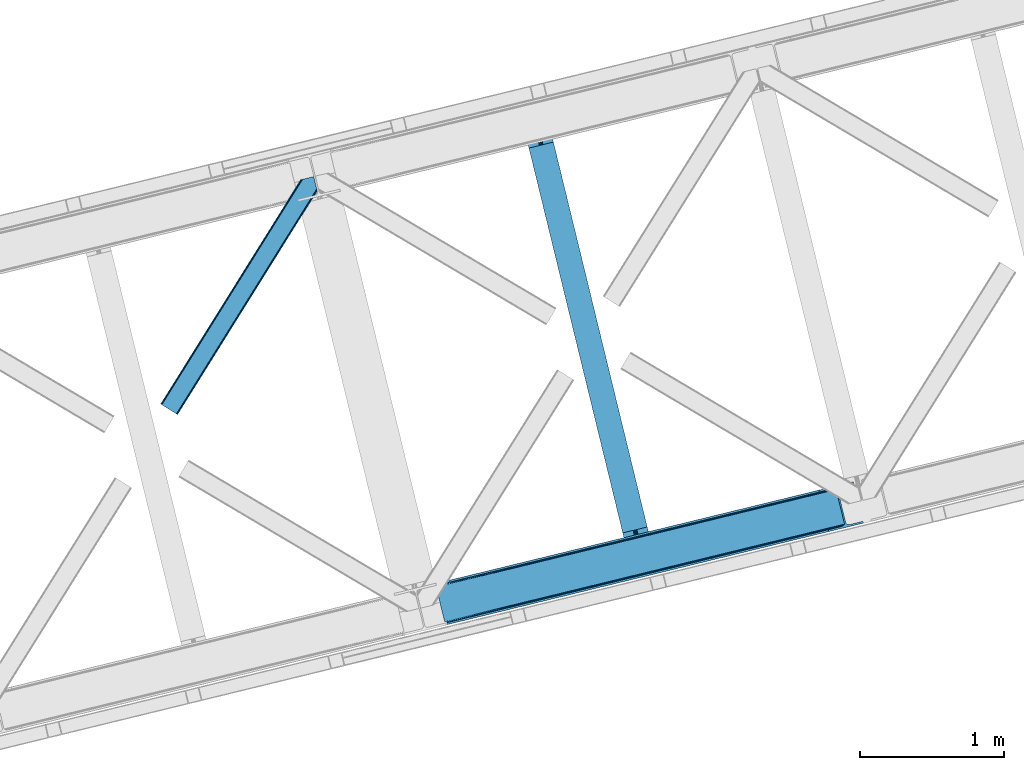
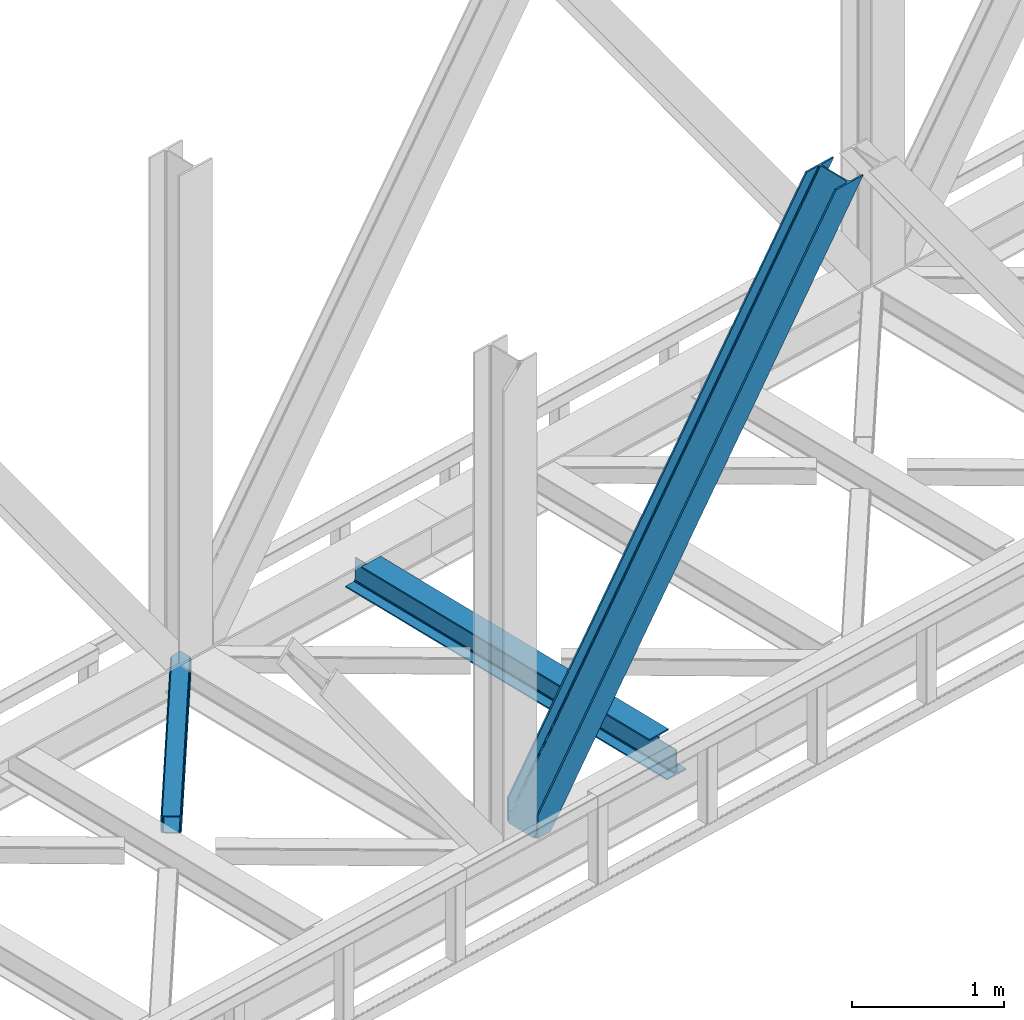
# One storey, part 62 of 93: 2 members, 1 beam.
"""IFC4 building model written with IfcOpenShell, lengths in millimetres."""

import ifcopenshell
import ifcopenshell.guid

model = None  # the IFC model being written
_history = None  # IfcOwnerHistory: only IFC2X3 demands one
_inside = {}  # id of a spatial element -> (the spatial element, [elements in it])
_under = {}  # id of a project, library or spatial element -> (it, [spatial elements below it])
_declared = {}  # id of a project -> (the project, [libraries it declares])
_typed = {}  # id of a type object -> (the type object, [elements of that type])
_made_of = {}  # id of a material, layer set ... -> (it, [elements and type objects made of it])


def new_model(schema):
    """Start an empty IFC model of exactly this schema.

    Asked for "IFC4X3", IfcOpenShell would pick the latest addendum, in which some entities
    have other attributes; the version numbers below select the first issue.
    IFC2X3 requires an IfcOwnerHistory on every rooted entity: one is made here for all.
    """
    global model, _history
    if schema == "IFC4X3":
        model = ifcopenshell.file(schema_version=(4, 3, 0, 0))
    else:
        model = ifcopenshell.file(schema=schema)
    _inside.clear()
    _under.clear()
    _declared.clear()
    _typed.clear()
    _made_of.clear()
    _history = None
    if model.schema == "IFC2X3":
        org = make("IfcOrganization", Name="unknown")
        user = make(
            "IfcPersonAndOrganization",
            ThePerson=make("IfcPerson", FamilyName="unknown"),
            TheOrganization=org,
        )
        app = make(
            "IfcApplication",
            ApplicationDeveloper=org,
            Version="unknown",
            ApplicationFullName="unknown",
            ApplicationIdentifier="unknown",
        )
        _history = make(
            "IfcOwnerHistory",
            OwningUser=user,
            OwningApplication=app,
            ChangeAction="ADDED",
            CreationDate=0,
        )
    return model


def make(cls, **values):
    """One entity of the class cls with the attributes given. An attribute that is None is left unset."""
    return model.create_entity(
        cls, **{name: value for name, value in values.items() if value is not None}
    )


def entity(cls, *values):
    """Any entity or typed value of the class cls, its attributes in the order of the schema. None: left unset."""
    e = model.create_entity(cls)
    for i, value in enumerate(values):
        if value is not None:
            e[i] = value
    return e


def rooted(cls, **values):
    """An entity with a GlobalId (a new one), such as an element, a storey or a relation."""
    return make(cls, GlobalId=ifcopenshell.guid.new(), OwnerHistory=_history, **values)


def si_unit(unit_type, name, prefix=None):
    """IfcSIUnit, for example si_unit("LENGTHUNIT", "METRE", prefix="MILLI")."""
    return make("IfcSIUnit", UnitType=unit_type, Prefix=prefix, Name=name)


def converted_unit(unit_type, name, factor, base, dimensions=None, offset=None):
    """IfcConversionBasedUnit, such as the inch: factor (a typed value) times the base unit."""
    return make(
        "IfcConversionBasedUnit"
        if offset is None
        else "IfcConversionBasedUnitWithOffset",
        ConversionOffset=offset,
        Dimensions=None
        if dimensions is None
        else entity("IfcDimensionalExponents", *dimensions),
        UnitType=unit_type,
        Name=name,
        ConversionFactor=make(
            "IfcMeasureWithUnit", ValueComponent=factor, UnitComponent=base
        ),
    )


def derived_unit(unit_type, elements):
    """IfcDerivedUnit: a product of units, each with its exponent."""
    return make(
        "IfcDerivedUnit",
        Elements=[
            make("IfcDerivedUnitElement", Unit=unit, Exponent=power)
            for unit, power in elements
        ],
        UnitType=unit_type,
    )


def assignment(units):
    """IfcUnitAssignment: the units of a project."""
    return None if units is None else make("IfcUnitAssignment", Units=units)


def point(xyz):
    """IfcCartesianPoint."""
    return None if xyz is None else make("IfcCartesianPoint", Coordinates=xyz)


def direction(xyz):
    """IfcDirection."""
    return None if xyz is None else make("IfcDirection", DirectionRatios=xyz)


def frame(location, z_axis=None, x_axis=None):
    """IfcAxis2Placement3D, a coordinate frame: its origin and axes. An axis left out is left unset."""
    return make(
        "IfcAxis2Placement3D",
        Location=point(location),
        Axis=direction(z_axis),
        RefDirection=direction(x_axis),
    )


def origin():
    """The frame at (0, 0, 0) with its axes left unset."""
    return frame((0.0, 0.0, 0.0))


def place(relative_to, where):
    """IfcLocalPlacement: puts the frame where relative to a parent placement (None: the world)."""
    return make(
        "IfcLocalPlacement", PlacementRelTo=relative_to, RelativePlacement=where
    )


def context(
    kind, dimensions, precision=None, world=None, true_north=None, identifier=None
):
    """IfcGeometricRepresentationContext, for example the 3D "Model" context."""
    return make(
        "IfcGeometricRepresentationContext",
        ContextIdentifier=identifier,
        ContextType=kind,
        CoordinateSpaceDimension=dimensions,
        Precision=precision,
        WorldCoordinateSystem=world,
        TrueNorth=true_north,
    )


def subcontext(parent, identifier, kind, view, scale=None):
    """IfcGeometricRepresentationSubContext, for example "Body" below "Model"."""
    return make(
        "IfcGeometricRepresentationSubContext",
        ContextIdentifier=identifier,
        ContextType=kind,
        ParentContext=parent,
        TargetScale=scale,
        TargetView=view,
    )


def project(units=None, contexts=None):
    """IfcProject with its units and contexts."""
    return rooted(
        "IfcProject",
        Name="project",
        RepresentationContexts=contexts,
        UnitsInContext=assignment(units),
    )


def spatial(cls, under=None, at=None, **own):
    """A site, building, storey or space (cls), placed at a placement, below another one or the project."""
    s = rooted(cls, ObjectPlacement=at, **own)
    if under is not None:
        _under.setdefault(under.id(), (under, []))[1].append(s)
    return s


def point_list(points):
    """IfcCartesianPointList2D or 3D."""
    cls = (
        "IfcCartesianPointList2D" if len(points[0]) == 2 else "IfcCartesianPointList3D"
    )
    return make(cls, CoordList=points)


def triangles(points, corners, closed=None, point_numbers=None):
    """IfcTriangulatedFaceSet: each triangle names its three corners, points numbered from 1."""
    return make(
        "IfcTriangulatedFaceSet",
        Coordinates=point_list(points),
        Closed=closed,
        CoordIndex=corners,
        PnIndex=point_numbers,
    )


def polygons(points, faces, closed=None, point_numbers=None):
    """IfcPolygonalFaceSet: a face is its outer loop, then its inner loops; points numbered from 1."""
    made = []
    for loops in faces:
        if len(loops) == 1:
            made.append(make("IfcIndexedPolygonalFace", CoordIndex=loops[0]))
        else:
            made.append(
                make(
                    "IfcIndexedPolygonalFaceWithVoids",
                    CoordIndex=loops[0],
                    InnerCoordIndices=loops[1:],
                )
            )
    return make(
        "IfcPolygonalFaceSet",
        Coordinates=point_list(points),
        Closed=closed,
        Faces=made,
        PnIndex=point_numbers,
    )


def shape(context_of_items, identifier, shape_type, items):
    """IfcShapeRepresentation: the items that make up one representation, for example the "Body"."""
    return make(
        "IfcShapeRepresentation",
        ContextOfItems=context_of_items,
        RepresentationIdentifier=identifier,
        RepresentationType=shape_type,
        Items=items,
    )


def material(Name=None, Category=None):
    """IfcMaterial."""
    return make("IfcMaterial", Name=Name, Category=Category)


def made_of(thing, what):
    """Note that an element or type object is made of a material, layer set ...; save() writes the relation."""
    if what is not None:
        _made_of.setdefault(what.id(), (what, []))[1].append(thing)
    return thing


def type_object(cls, material=None, **own):
    """A type object (cls), such as IfcWallType, which elements share."""
    return made_of(rooted(cls, **own), material)


def element(
    cls,
    number,
    at=None,
    inside=None,
    cuts=None,
    type_object=None,
    material=None,
    context=None,
    identifier="Body",
    shape_type=None,
    held_by="IfcProductDefinitionShape",
    body=None,
    shapes=None,
    **own,
):
    """One element of the class cls, such as IfcWall. Its Tag is "e" and its number.

    at: its placement. inside: the storey or other place that contains it. cuts: it is an
    opening in that element (IfcRelVoidsElement). A single representation is given by context,
    identifier, shape_type and body (its items); several are given by shapes. held_by: the class
    of the entity that holds the representations. save() writes the other relations.
    """
    e = rooted(cls, Tag="e%d" % number, ObjectPlacement=at, **own)
    if body is not None:
        shapes = [shape(context, identifier, shape_type, body)]
    if shapes is not None:
        e.Representation = make(held_by, Representations=shapes)
    if inside is not None:
        _inside.setdefault(inside.id(), (inside, []))[1].append(e)
    if cuts is not None:
        rooted(
            "IfcRelVoidsElement", RelatingBuildingElement=cuts, RelatedOpeningElement=e
        )
    if type_object is not None:
        _typed.setdefault(type_object.id(), (type_object, []))[1].append(e)
    return made_of(e, material)


def aggregate(whole, parts):
    """IfcRelAggregates: a whole, such as a stair, and the parts it consists of."""
    return rooted("IfcRelAggregates", RelatingObject=whole, RelatedObjects=parts)


def save(model, path):
    """Write the relations noted so far, then the file.

    IfcRelAggregates (storeys below a building ...), IfcRelContainedInSpatialStructure (elements
    in a storey), IfcRelDefinesByType, IfcRelAssociatesMaterial and IfcRelDeclares: one each for
    every whole, place, type object, material and project.
    """
    for whole, parts in _under.values():
        aggregate(whole, parts)
    for where, things in _inside.values():
        rooted(
            "IfcRelContainedInSpatialStructure",
            RelatedElements=things,
            RelatingStructure=where,
        )
    for kind, things in _typed.values():
        rooted("IfcRelDefinesByType", RelatedObjects=things, RelatingType=kind)
    for what, things in _made_of.values():
        rooted("IfcRelAssociatesMaterial", RelatedObjects=things, RelatingMaterial=what)
    for by, libraries in _declared.values():
        rooted("IfcRelDeclares", RelatingContext=by, RelatedDefinitions=libraries)
    model.write(path)


model = new_model("IFC4")

# Units and contexts
model_context = context("Model", 3, precision=0.01, world=origin(), true_north=direction((6.12303176911189e-17, 1.0)))
plan_context = context("Plan", 3, precision=0.01, world=origin(), true_north=direction((6.12303176911189e-17, 1.0)))
body_context = subcontext(model_context, "Body", "Model", "MODEL_VIEW")
ifc_project = project(units=[si_unit("LENGTHUNIT", "METRE", prefix="MILLI"), si_unit("AREAUNIT", "SQUARE_METRE"), si_unit("VOLUMEUNIT", "CUBIC_METRE"), converted_unit("PLANEANGLEUNIT", "DEGREE", entity("IfcRatioMeasure", 0.0174532925199433), si_unit("PLANEANGLEUNIT", "RADIAN"), dimensions=[0, 0, 0, 0, 0, 0, 0]), si_unit("MASSUNIT", "GRAM", prefix="KILO"), derived_unit("MASSDENSITYUNIT", [(si_unit("MASSUNIT", "GRAM", prefix="KILO"), 1), (si_unit("LENGTHUNIT", "METRE"), -3)]), derived_unit("MOMENTOFINERTIAUNIT", [(si_unit("LENGTHUNIT", "METRE"), 4)]), si_unit("TIMEUNIT", "SECOND"), si_unit("FREQUENCYUNIT", "HERTZ"), si_unit("THERMODYNAMICTEMPERATUREUNIT", "DEGREE_CELSIUS"), derived_unit("THERMALTRANSMITTANCEUNIT", [(si_unit("MASSUNIT", "GRAM", prefix="KILO"), 1), (si_unit("THERMODYNAMICTEMPERATUREUNIT", "KELVIN"), -1), (si_unit("TIMEUNIT", "SECOND"), -3)]), derived_unit("VOLUMETRICFLOWRATEUNIT", [(si_unit("LENGTHUNIT", "METRE"), 3), (si_unit("TIMEUNIT", "SECOND"), -1)]), derived_unit("MASSFLOWRATEUNIT", [(si_unit("MASSUNIT", "GRAM", prefix="KILO"), 1), (si_unit("TIMEUNIT", "SECOND"), -1)]), derived_unit("ROTATIONALFREQUENCYUNIT", [(si_unit("TIMEUNIT", "SECOND"), -1)]), si_unit("ELECTRICCURRENTUNIT", "AMPERE"), si_unit("ELECTRICVOLTAGEUNIT", "VOLT"), si_unit("POWERUNIT", "WATT"), si_unit("FORCEUNIT", "NEWTON", prefix="KILO"), si_unit("ILLUMINANCEUNIT", "LUX"), si_unit("LUMINOUSFLUXUNIT", "LUMEN"), si_unit("LUMINOUSINTENSITYUNIT", "CANDELA"), derived_unit("USERDEFINED", [(si_unit("MASSUNIT", "GRAM", prefix="KILO"), -1), (si_unit("LENGTHUNIT", "METRE"), -2), (si_unit("TIMEUNIT", "SECOND"), 3), (si_unit("LUMINOUSFLUXUNIT", "LUMEN"), 1)]), derived_unit("LINEARVELOCITYUNIT", [(si_unit("LENGTHUNIT", "METRE"), 1), (si_unit("TIMEUNIT", "SECOND"), -1)]), si_unit("PRESSUREUNIT", "PASCAL"), derived_unit("USERDEFINED", [(si_unit("LENGTHUNIT", "METRE"), -2), (si_unit("MASSUNIT", "GRAM", prefix="KILO"), 1), (si_unit("TIMEUNIT", "SECOND"), -2)]), derived_unit("LINEARFORCEUNIT", [(si_unit("MASSUNIT", "GRAM", prefix="KILO"), 1), (si_unit("LENGTHUNIT", "METRE"), 1), (si_unit("TIMEUNIT", "SECOND"), -2), (si_unit("LENGTHUNIT", "METRE"), -1)]), derived_unit("PLANARFORCEUNIT", [(si_unit("MASSUNIT", "GRAM", prefix="KILO"), 1), (si_unit("LENGTHUNIT", "METRE"), 1), (si_unit("TIMEUNIT", "SECOND"), -2), (si_unit("LENGTHUNIT", "METRE"), -2)])], contexts=[model_context, plan_context])

# Site, building, storey
site_placement = place(None, origin())
site = spatial("IfcSite", under=ifc_project, at=site_placement, CompositionType="ELEMENT")
building_placement = place(site_placement, origin())
building = spatial("IfcBuilding", under=site, at=building_placement, CompositionType="ELEMENT")
storey_placement = place(building_placement, frame((0.0, 0.0, 15900.0)))
storey = spatial("IfcBuildingStorey", under=building, at=storey_placement, CompositionType="ELEMENT", Elevation=15900.0)

# Beam
ifc_material = material(Name="Metal painted (White)")
beam_type = type_object("IfcBeamType", PredefinedType="BEAM")
beam_placement = place(storey_placement, frame((-22569.0463868615, 12291.2993879152, 3441.0)))
element("IfcBeam", 1, at=beam_placement, inside=storey, type_object=beam_type, material=ifc_material, ObjectType="Steel Beam", PredefinedType="BEAM", context=body_context, shape_type="Tessellation", body=[
    polygons([(897.255335224839, 41.4445662733081, 11.000000000004), (897.255335224839, 41.4445662733081, 2.16573425859679e-12), (170.021610174761, 3024.83804881124, 2.16573425859679e-12), (170.021610174761, 3024.83804881124, 11.000000000004), (831.189795271217, 25.3403919499634, 11.000000000004), (103.956070221135, 3008.73387448789, 11.000000000004), (825.24104524992, 23.8903211957374, 12.2179274798217), (98.0073201998383, 3007.28380373367, 12.2179274798217), (820.197938493812, 22.6610105689172, 15.686291501017), (92.964213443734, 3006.05449310684, 15.686291501017), (816.828242290632, 21.8396114687075, 20.8770650821657), (89.5945172405538, 3005.23309400664, 20.8770650821657), (815.644962340954, 21.5511744621184, 27.0000000000047), (88.4112372908809, 3004.94465700005, 27.0000000000047), (81.6103728838758, 3003.28687434912, 27.0000000000047), (81.6103728838758, 3003.28687434912, 203.000000000006), (88.4112372908766, 3004.94465700005, 203.000000000006), (0.0, 2983.39348253793, 2.16573425859679e-12), (0.0, 2983.39348253793, 10.9999999999997), (66.0655399536129, 2999.49765686127, 11.000000000004), (72.0142899749184, 3000.9477276155, 12.2179274798217), (77.0573967310226, 3002.17703824232, 15.6862915010192), (80.4270929342029, 3002.99843734253, 20.8770650821657), (815.644962340954, 21.5511744621184, 203.000000000006), (808.844097933954, 19.8933918111854, 203.000000000006), (808.844097933949, 19.8933918111832, 27.0000000000047), (807.660817984281, 19.6049548045963, 20.8770650821657), (804.2911217811, 18.7835557043887, 15.6862915010192), (799.248015024996, 17.5542450775685, 12.2179274798217), (793.299265003691, 16.1041743233403, 11.000000000004), (727.233725050078, -2.16573425859679e-12, 10.9999999999997), (727.233725050078, -2.16573425859679e-12, 2.16573425859679e-12), (775.945201918152, 184.415062601688, 203.069791966819), (124.290390378902, 2857.75452019161, 203.000000000006), (124.513271168057, 2856.84017775719, 203.617301946336), (124.526185412576, 2856.78719778429, 217.000003693143), (775.799998669227, 185.010597404067, 217.000003676718), (775.800869277121, 185.007025963188, 204.00000679514), (769.234900753718, 182.385463974441, 203.006342981529), (769.012053092176, 183.299815969772, 203.617301946336), (768.999138847653, 183.352795942665, 217.000003693143), (117.725325591002, 2855.12939632289, 217.000003676718), (117.724454983108, 2855.13296776377, 204.00000679514), (117.580155394058, 2855.72494066435, 203.076120467494), (117.489525971914, 2856.09673754068, 203.000000000006), (776.983483393258, 185.29819437751, 223.122939328039), (780.352479801942, 186.122464201391, 228.313710402595), (785.395115205961, 187.353708426697, 231.782072735464), (791.343694076665, 188.804481281377, 232.999999602236), (857.409144942193, 204.909021065315, 232.999999283132), (857.407671605755, 204.915065042188, 243.999994005812), (687.386290701838, 163.469558245295, 243.999994827032), (687.387764038276, 163.463514268422, 233.000000104353), (753.453214903791, 179.568054052354, 232.999999785253), (759.402120032129, 181.017488520582, 231.782072861012), (764.445684539256, 182.244921343716, 228.313710479427), (767.816071449001, 183.063487001146, 223.12293937232), (116.541840866979, 2854.84179934945, 223.122939328039), (113.172844458296, 2854.01752952557, 228.313710402595), (108.130209054276, 2852.78628530026, 231.782072735464), (102.18163018356, 2851.33551244558, 232.999999602236), (36.1161793180448, 2835.23097266165, 232.999999283128), (36.1176526544823, 2835.22492868478, 243.999994005812), (206.139033558399, 2876.67043548167, 243.999994827032), (206.137560221961, 2876.67647945854, 233.000000104357), (140.072109356438, 2860.57193967461, 232.999999785253), (134.123204228108, 2859.12250520638, 231.782072861012), (129.079639720977, 2857.89507238325, 228.313710479427), (125.709252811232, 2857.07650672581, 223.12293937232)], [[[1, 2, 3, 4]], [[5, 1, 4, 6]], [[7, 5, 6, 8]], [[9, 7, 8, 10]], [[11, 9, 10, 12]], [[13, 11, 12, 14]], [[15, 16, 17, 14, 12, 10, 8, 6, 4, 3, 18, 19, 20, 21, 22, 23]], [[13, 24, 25, 26, 27, 28, 29, 30, 31, 32, 2, 1, 5, 7, 9, 11]], [[2, 32, 18, 3]], [[32, 31, 19, 18]], [[31, 30, 20, 19]], [[27, 26, 15, 23]], [[28, 27, 23, 22]], [[29, 28, 22, 21]], [[30, 29, 21, 20]], [[33, 24, 13, 14, 17, 34, 35, 36, 37, 38]], [[25, 39, 40, 41, 42, 43, 44, 16, 15, 26]], [[39, 25, 24, 33]], [[45, 34, 17, 16]], [[41, 40, 38, 37, 46, 47, 48, 49, 50, 51, 52, 53, 54, 55, 56, 57]], [[42, 58, 59, 60, 61, 62, 63, 64, 65, 66, 67, 68, 69, 36, 35, 43]], [[46, 37, 36, 69]], [[47, 46, 69, 68]], [[48, 47, 68, 67]], [[49, 48, 67, 66]], [[50, 49, 66, 65]], [[51, 50, 65, 64]], [[52, 51, 64, 63]], [[53, 52, 63, 62]], [[54, 53, 62, 61]], [[55, 54, 61, 60]], [[56, 55, 60, 59]], [[57, 56, 59, 58]], [[41, 57, 58, 42]]], closed=False),
])

# Members
member_type_1 = type_object("IfcMemberType", PredefinedType="BRACE")
member_1_placement = place(storey_placement, frame((-23178.4991638184, 11819.308795166, 3694.99929199219)))
element("IfcMember", 2, at=member_1_placement, inside=storey, type_object=member_type_1, ObjectType="Steel Vertical Brace", PredefinedType="BRACE", context=body_context, shape_type="Tessellation", body=[
    triangles([(58.5475891113274, 26.6239562988285, 0.0), (60.4404968261733, 18.8511749267582, 0.0), (59.1056945800774, 19.6697296142574, 0.80925292968459), (58.9708190917954, 18.4930572509766, 1.10690917968532), (64.089111328125, 19.7406555175785, 8.31577148437282), (64.089111328125, 19.7406555175785, 0.0), (522.907617187499, 126.716683959961, 658.855133056641), (68.3748962402351, 19.9243652343739, 14.8293273925774), (72.4072082519524, 18.4523620605469, 22.4381652832017), (524.586584472658, 133.136059570312, 656.552947998047), (73.9861816406265, 17.2873168945316, 26.4425720214822), (2834.75487670898, 696.264477539062, 3911.00081176758), (2834.77348022461, 703.35823059082, 3911.00081176758), (2385.95203857422, 593.953280639647, 3278.7231262207), (2386.50781860352, 586.999053955078, 3279.53005371094), (2831.44345092773, 689.4462890625, 3911.00081176758), (2384.82652587891, 580.578515625, 3281.83223876953), (2825.34149780274, 683.941973876952, 3911.00081176758), (2381.17326049805, 575.671838378907, 3285.27854003906), (2817.37919311523, 680.591015624999, 3911.00081176758), (2376.09450073242, 573.023162841797, 3289.34108276367), (514.170941162109, 119.160168457031, 666.36397705078), (519.249700927736, 121.80884399414, 662.301434326171), (77.0999450683594, 12.6189971923832, 50.6410949707024), (76.5674194335952, 13.9003143310547, 38.6743835449197), (75.4046997070327, 15.4258026123043, 33.1630920410134), (524.028479003908, 140.090286254883, 655.74602050781), (990.06514892578, 246.601226806641, 1312.29896850586), (989.509368896484, 253.556616210937, 1311.48971557617), (1455.54603881836, 360.067556762695, 1968.04266357422), (1454.99025878906, 367.021783447266, 1967.23341064453), (1921.02692871094, 473.533886718749, 2623.78635864258), (1920.47114868164, 480.48811340332, 2622.97710571289), (988.386181640624, 240.181851196288, 1314.598828125), (1453.8670715332, 353.647018432617, 1970.34484863281), (1919.34796142578, 467.113348388672, 2626.08854370117), (984.732916259767, 235.275173950195, 1318.04512939453), (1450.21380615234, 348.740341186523, 1973.78882446289), (1915.69469604492, 462.206671142578, 2629.53251953125), (979.651831054689, 232.626498413085, 1322.10767211914), (1445.13272094727, 346.091665649414, 1977.85369262695), (1910.61361083984, 459.557995605468, 2633.59738769531), (77.0999450683594, 12.6189971923832, 182.433050537107), (2723.82676391601, 657.786593627929, 3911.00081176758), (75.5698059082024, 15.5502136230461, 0.0), (77.3789978027344, 11.6585906982418, 0.0), (77.3789978027344, 11.6585906982418, 182.495837402341), (68.3748962402351, 19.9243652343739, 0.0), (72.4072082519524, 18.4523620605469, 0.0), (2726.9033203125, 645.157131958007, 3911.00081176758), (80.2206848144524, 0.0, 182.495837402341), (80.2206848144524, 0.0, 0.0), (191.327856445314, 27.0832305908207, 0.0), (2967.5537475586, 703.817504882813, 3911.00081176758), (1399.80990600586, 593.394012451172, 1967.23341064453), (2779.59312744141, 929.730459594726, 3911.00081176758), (2330.77168579102, 820.325509643555, 3278.7231262207), (1865.29079589844, 706.859179687499, 2622.97710571289), (934.329016113283, 479.927682495118, 1311.48971557617), (468.848126220702, 366.461352539061, 655.74602050781), (3.36723632812573, 252.996185302734, 0.0), (2964.47486572266, 716.448129272461, 3911.00081176758), (188.248974609374, 39.7138549804677, 0.0), (2870.92243652344, 693.643707275391, 3911.00081176758), (94.6965454101555, 16.9094329833988, 0.0), (2862.31133422851, 692.954214477539, 3911.00081176758), (86.083117675782, 16.2199401855469, 0.0), (2854.36065673828, 695.033157348633, 3911.00081176758), (78.1324401855454, 18.2977203369137, 0.0), (2848.28428344726, 699.561950683594, 3911.00081176758), (72.0560668945327, 22.8265136718746, 0.0), (2845.00308837891, 705.852264404297, 3911.00081176758), (68.7748718261719, 29.1168273925778, 0.0), (2789.8227355957, 932.223330688475, 3911.00081176758), (13.5945190429702, 255.489056396484, 0.0), (2789.84133911133, 939.318246459961, 3911.00081176758), (13.6131225585923, 262.582809448242, 0.0), (2793.15276489258, 946.136434936523, 3911.00081176758), (16.9245483398445, 269.400997924804, 0.0), (2799.25471801758, 951.639587402344, 3911.00081176758), (23.026501464843, 274.904150390625, 0.0), (2807.21702270508, 954.990545654297, 3911.00081176758), (30.9911315917961, 278.256271362305, 0.0), (2900.7694519043, 977.794967651367, 3911.00081176758), (124.543560791015, 301.060693359375, 0.0), (2897.69057006836, 990.425592041016, 3911.00081176758), (121.464678955079, 313.691317749022, 0.0), (2770.23323364258, 940.54956665039, 3911.00081176758), (2762.28255615234, 942.627346801757, 3911.00081176758), (2657.04014282226, 931.764056396483, 3911.00081176758), (2753.67145385742, 941.939016723632, 3911.00081176758), (2660.1190246582, 919.134594726562, 3911.00081176758), (2776.31193237305, 936.020773315429, 3911.00081176758), (10.3575073242173, 286.608087158203, 182.495837402341), (10.3575073242173, 286.608087158203, 0.0), (13.199194335939, 274.94949645996, 182.495837402341), (13.39453125, 273.966998291015, 182.433050537107), (1381.42730712891, 607.439666748047, 1977.85369262695), (1846.90819702148, 720.904833984374, 2633.59738769531), (2312.38908691406, 834.37116394043, 3289.34108276367), (915.94641723633, 493.973336791993, 1322.10767211914), (13.39453125, 273.966998291015, 50.6410949707024), (450.463201904298, 380.507006835936, 666.36397705078), (13.199194335939, 274.94949645996, 0.0), (13.5108032226563, 272.584524536132, 38.6743835449197), (13.3829040527344, 270.661386108399, 0.0), (13.3829040527344, 270.661386108399, 32.1678039550752), (12.4783081054702, 268.182467651366, 26.1867736816384), (11.9132263183601, 266.62907409668, 22.4381652832017), (11.9132263183601, 266.62907409668, 0.0), (9.00875244140479, 263.467639160155, 14.8293273925774), (9.00875244140479, 263.467639160155, 0.0), (5.11829223632958, 261.657284545898, 8.31577148437282), (5.11829223632958, 261.657284545898, 0.0), (1.47200317382885, 260.767803955077, 0.0), (461.697399902343, 377.819961547852, 658.855133056641), (456.193084716797, 380.493054199218, 662.301434326171), (466.143640136717, 372.892355346679, 656.552947998047), (0.662750244140625, 259.426025390625, 0.80925292968459), (0.0, 260.409686279296, 1.10690917968532), (2318.11664428711, 834.35721130371, 3285.27854003906), (2323.6186340332, 831.681793212891, 3281.83223876953), (2328.06487426758, 826.755349731446, 3279.53005371094), (921.676300048828, 493.959384155272, 1318.04512939453), (1387.15486450195, 607.425714111328, 1973.78882446289), (1852.63575439453, 720.892044067383, 2629.53251953125), (927.175964355469, 491.285128784179, 1314.598828125), (1392.65685424805, 604.750296020507, 1970.34484863281), (1858.13774414063, 718.216625976562, 2626.08854370117), (931.622204589843, 486.357522583008, 1312.29896850586), (1397.10309448242, 599.823852539063, 1968.04266357422), (1862.583984375, 713.290182495117, 2623.78635864258)], [[1, 2, 3], [4, 3, 2], [5, 4, 6], [2, 6, 4], [7, 8, 9], [10, 3, 8], [8, 7, 10], [9, 11, 7], [3, 4, 5], [5, 8, 3], [12, 13, 14], [14, 15, 12], [16, 12, 15], [15, 17, 16], [18, 16, 17], [17, 19, 18], [20, 18, 19], [19, 21, 20], [22, 23, 24], [25, 24, 23], [25, 7, 26], [25, 23, 7], [11, 26, 7], [10, 27, 3], [1, 3, 27], [28, 29, 10], [27, 10, 29], [30, 31, 28], [29, 28, 31], [32, 33, 31], [31, 30, 32], [15, 14, 33], [33, 32, 15], [34, 28, 7], [10, 7, 28], [35, 30, 34], [28, 34, 30], [36, 32, 35], [30, 35, 32], [17, 15, 36], [32, 36, 15], [37, 34, 7], [7, 23, 37], [38, 35, 34], [34, 37, 38], [39, 36, 35], [35, 38, 39], [19, 17, 36], [36, 39, 19], [40, 37, 22], [23, 22, 37], [41, 38, 40], [37, 40, 38], [42, 39, 41], [38, 41, 39], [21, 19, 42], [39, 42, 19], [41, 43, 44], [44, 21, 42], [21, 44, 20], [42, 41, 44], [43, 41, 40], [40, 22, 43], [24, 43, 22], [45, 11, 9], [45, 26, 11], [46, 25, 26], [46, 47, 24], [43, 24, 47], [24, 25, 46], [26, 45, 46], [48, 8, 5], [5, 6, 48], [49, 9, 8], [8, 48, 49], [9, 49, 45], [47, 44, 43], [50, 47, 51], [47, 50, 44], [52, 51, 46], [47, 46, 51], [50, 53, 54], [53, 50, 51], [52, 53, 51], [33, 55, 31], [13, 56, 57], [58, 14, 57], [55, 33, 58], [57, 14, 13], [58, 33, 14], [31, 59, 29], [59, 60, 27], [59, 31, 55], [61, 1, 60], [59, 27, 29], [60, 1, 27], [62, 54, 53], [53, 63, 62], [64, 62, 63], [63, 65, 64], [66, 64, 65], [65, 67, 66], [68, 66, 67], [67, 69, 68], [70, 68, 69], [69, 71, 70], [72, 70, 71], [71, 73, 72], [74, 72, 75], [73, 75, 72], [76, 74, 77], [75, 77, 74], [78, 76, 79], [77, 79, 76], [80, 78, 81], [79, 81, 78], [82, 80, 83], [81, 83, 80], [84, 82, 85], [83, 85, 82], [86, 84, 85], [85, 87, 86], [56, 13, 74], [16, 18, 66], [20, 50, 54], [44, 50, 20], [18, 20, 64], [13, 12, 70], [12, 16, 68], [88, 80, 89], [90, 91, 86], [91, 89, 82], [90, 92, 91], [88, 93, 78], [93, 56, 76], [74, 13, 72], [64, 66, 18], [70, 12, 68], [66, 68, 16], [70, 72, 13], [54, 64, 20], [54, 62, 64], [82, 89, 80], [78, 93, 76], [74, 76, 56], [78, 80, 88], [82, 86, 91], [86, 82, 84], [90, 87, 94], [90, 86, 87], [87, 95, 94], [96, 90, 94], [92, 96, 97], [96, 92, 90], [92, 97, 98], [98, 99, 92], [99, 100, 92], [91, 92, 100], [101, 98, 97], [97, 102, 103], [103, 101, 97], [104, 96, 94], [94, 95, 104], [104, 105, 102], [104, 106, 107], [107, 105, 104], [96, 104, 102], [102, 97, 96], [108, 106, 109], [108, 107, 106], [110, 109, 106], [109, 110, 111], [112, 111, 110], [111, 112, 113], [114, 113, 112], [75, 73, 61], [114, 75, 61], [114, 112, 75], [114, 61, 115], [79, 77, 110], [77, 75, 112], [106, 79, 110], [110, 77, 112], [73, 1, 61], [6, 73, 48], [1, 6, 2], [1, 73, 6], [48, 71, 49], [49, 71, 69], [73, 71, 48], [45, 49, 69], [104, 81, 79], [79, 106, 104], [95, 81, 104], [83, 95, 87], [87, 85, 83], [83, 81, 95], [45, 69, 46], [52, 67, 65], [46, 69, 67], [52, 46, 67], [65, 53, 52], [53, 65, 63], [116, 117, 105], [105, 107, 116], [118, 111, 113], [113, 119, 118], [118, 116, 108], [108, 109, 118], [109, 111, 118], [113, 120, 119], [107, 108, 116], [117, 103, 102], [102, 105, 117], [89, 91, 121], [100, 121, 91], [88, 89, 122], [121, 122, 89], [93, 88, 123], [122, 123, 88], [56, 93, 57], [123, 57, 93], [124, 101, 103], [103, 117, 124], [125, 98, 101], [101, 124, 125], [126, 99, 98], [98, 125, 126], [121, 100, 99], [99, 126, 121], [127, 124, 116], [117, 116, 124], [128, 125, 127], [124, 127, 125], [129, 126, 128], [125, 128, 126], [122, 121, 129], [126, 129, 121], [130, 127, 116], [116, 118, 130], [131, 128, 130], [127, 130, 128], [132, 129, 131], [128, 131, 129], [123, 122, 129], [129, 132, 123], [60, 118, 119], [119, 61, 60], [59, 130, 118], [118, 60, 59], [55, 131, 130], [130, 59, 55], [58, 132, 131], [131, 55, 58], [57, 123, 58], [132, 58, 123], [120, 113, 114], [114, 115, 120], [115, 61, 119], [119, 120, 115]]),
])
member_type_2 = type_object("IfcMemberType", PredefinedType="BRACE")
member_2_placement = place(storey_placement, frame((-25090.0569030762, 13275.8570983887, 3510.00011901855)))
element("IfcMember", 3, at=member_2_placement, inside=storey, type_object=member_type_2, ObjectType="Steel Horizontal Brace", PredefinedType="BRACE", context=body_context, shape_type="Tessellation", body=[
    triangles([(933.019793701173, 1535.69230957031, 0.0), (967.780462646486, 1393.09171142578, 0.0), (14.8456054687485, 64.8704589843746, 0.0), (103.916912841796, 9.2680389404286, 0.0), (928.803771972656, 1552.99125366211, 5.49966430664063), (928.943298339844, 1552.41687011719, 5.20782165527635), (930.803649902344, 1544.78710327148, 1.33247680664135), (971.996484374999, 1375.79276733398, 5.49966430664063), (971.856958007811, 1376.36715087891, 5.20782165527635), (969.996606445311, 1383.99691772461, 1.33247680664135), (972.210424804689, 1375.53813171387, 5.85313110351854), (972.422039794921, 1375.28349609375, 6.20659790039281), (928.913067626952, 1553.56912536621, 5.74383544921875), (972.724346923827, 1375.53813171387, 6.35310058594041), (929.029339599609, 1554.1772277832, 5.9996337890625), (973.026654052734, 1375.79276733398, 6.49960327148438), (929.143286132814, 1554.78416748047, 6.25659484863354), (929.254907226561, 1555.36203918457, 6.49960327148438), (4.34857177734375, 71.4223846435543, 5.12526855468968), (1.13248901367115, 73.4315643310547, 10.8028289794929), (973.359191894531, 1630.84347839355, 10.8028289794929), (976.914788818358, 1631.70970458984, 6.49960327148438), (9.16455688476708, 68.415591430663, 1.33247680664135), (971.508142089842, 1630.39118041992, 17.5000946044929), (0.0, 74.1361724853505, 17.5000946044929), (1081.10145263672, 1548.91708374023, 6.49960327148438), (1056.20762329101, 1651.03759460449, 6.49960327148438), (971.508142089842, 1630.39118041992, 122.500662231447), (0.0, 74.1361724853505, 122.500662231447), (973.359191894531, 1630.84347839355, 129.197927856447), (1.13248901367115, 73.4315643310547, 129.197927856447), (978.633288574219, 1632.12828369141, 134.874325561526), (4.34857177734375, 71.4223846435543, 134.874325561526), (986.525830078124, 1634.05258483887, 138.667117309571), (9.16455688476708, 68.415591430663, 138.667117309571), (995.83921508789, 1636.32221374512, 139.999594116212), (14.8456054687485, 64.8704589843746, 139.999594116212), (118.760192871094, 0.0, 17.5000946044929), (117.630029296874, 0.705770874023074, 10.8028289794929), (1085.14306640625, 1551.25066223144, 10.9783996582046), (1087.41734619141, 1552.56453552246, 13.5003387451179), (109.595635986327, 5.7205810546875, 1.33247680664135), (114.41162109375, 2.71495056152344, 5.12526855468968), (1087.56849975586, 1551.93550415039, 17.5000946044929), (1081.77583007812, 1575.70149536133, 139.999594116212), (1063.00720825195, 1652.69563293457, 139.999594116212), (103.916912841796, 9.2680389404286, 139.999594116212), (1083.99429931641, 1566.60670166016, 138.667117309571), (109.595635986327, 5.7205810546875, 138.667117309571), (1085.87325439453, 1558.89670715332, 134.874325561526), (114.41162109375, 2.71495056152344, 134.874325561526), (1087.12899169922, 1553.74469604492, 129.197927856447), (117.630029296874, 0.705770874023074, 129.197927856447), (1087.56849975586, 1551.93550415039, 122.500662231447), (118.760192871094, 0.0, 122.500662231447), (1082.53857421875, 1566.77297058105, 12.1260040283232), (1083.96406860352, 1566.72413635254, 13.5003387451179), (1077.85048828125, 1569.98556518555, 8.3320495605476), (1074.6483581543, 1577.50138549805, 6.99957275390625), (1056.69364013672, 1651.1561920166, 6.99957275390625), (1005.57350463867, 1638.69532470703, 6.99957275390625), (20.784777832032, 61.1625457763657, 6.99957275390625), (97.9754150390618, 12.9736267089829, 6.99957275390625), (108.47244873047, 6.42053833007776, 12.1260040283232), (111.690856933594, 4.41252136230469, 17.8035644531265), (1084.81052856445, 1563.2510925293, 17.8035644531265), (103.656463623047, 9.42733154296729, 8.3320495605476), (1085.25236206055, 1561.44190063477, 24.4996673583992), (112.823345947265, 3.70675048827979, 24.4996673583992), (983.093481445314, 1633.21542663574, 17.8035644531265), (981.24010620117, 1632.76429138184, 24.4996673583992), (7.0693359375, 69.7248138427731, 17.8035644531265), (5.93917236327979, 70.4305847167961, 24.4996673583992), (988.365252685548, 1634.50139465332, 12.1260040283232), (10.2877441406235, 67.7156341552727, 12.1260040283232), (996.262445068358, 1636.42569580078, 8.3320495605476), (15.1037292480469, 64.7100036621086, 8.3320495605476), (981.24010620117, 1632.76429138184, 115.501089477541), (5.93917236327979, 70.4305847167961, 115.501089477541), (996.262445068358, 1636.42569580078, 131.667544555665), (1005.57350463867, 1638.69532470703, 133.000021362306), (1063.00720825195, 1652.69563293457, 133.000021362306), (988.365252685548, 1634.50139465332, 127.87475280762), (983.093481445314, 1633.21542663574, 122.196029663086), (20.784777832032, 61.1625457763657, 133.000021362306), (15.1037292480469, 64.7100036621086, 131.667544555665), (10.2877441406235, 67.7156341552727, 127.87475280762), (7.0693359375, 69.7248138427731, 122.196029663086), (108.47244873047, 6.42053833007776, 127.87475280762), (111.690856933594, 4.41252136230469, 122.196029663086), (112.823345947265, 3.70675048827979, 115.501089477541), (97.9754150390618, 12.9736267089829, 133.000021362306), (103.656463623047, 9.42733154296729, 131.667544555665), (1085.25236206055, 1561.44190063477, 115.501089477541), (1084.81052856445, 1563.2510925293, 122.196029663086), (1083.55479125976, 1568.40310363769, 127.87475280762), (1081.67583618164, 1576.11309814453, 131.667544555665), (1079.45969238281, 1585.20905456543, 133.000021362306)], [[1, 2, 3], [4, 3, 2], [1, 5, 2], [6, 5, 1], [1, 7, 6], [2, 5, 8], [8, 9, 2], [10, 2, 9], [11, 8, 5], [12, 11, 13], [14, 12, 15], [16, 14, 17], [17, 18, 16], [15, 17, 14], [13, 15, 12], [5, 13, 11], [17, 19, 18], [19, 17, 15], [13, 19, 15], [19, 13, 5], [5, 6, 19], [20, 21, 18], [18, 19, 20], [21, 22, 18], [19, 6, 7], [7, 1, 23], [3, 23, 1], [7, 23, 19], [24, 21, 20], [20, 25, 24], [18, 26, 16], [26, 18, 22], [27, 26, 22], [28, 24, 25], [25, 29, 28], [30, 28, 31], [29, 31, 28], [32, 30, 33], [31, 33, 30], [34, 32, 35], [33, 35, 32], [36, 34, 37], [35, 37, 34], [38, 39, 40], [40, 41, 38], [42, 10, 9], [39, 12, 16], [16, 40, 39], [16, 26, 40], [9, 39, 43], [9, 12, 39], [9, 43, 42], [2, 10, 4], [42, 4, 10], [41, 44, 38], [45, 36, 37], [36, 45, 46], [37, 47, 45], [48, 45, 47], [47, 49, 48], [50, 48, 49], [49, 51, 50], [52, 50, 51], [51, 53, 52], [54, 52, 53], [53, 55, 54], [44, 54, 38], [55, 38, 54], [56, 40, 26], [41, 40, 56], [56, 57, 41], [58, 26, 59], [26, 58, 56], [60, 59, 26], [59, 61, 62], [61, 59, 60], [62, 63, 59], [64, 65, 66], [66, 57, 64], [58, 59, 63], [63, 67, 58], [56, 58, 67], [67, 64, 56], [57, 56, 64], [68, 66, 65], [65, 69, 68], [70, 71, 72], [73, 72, 71], [74, 70, 75], [72, 75, 70], [76, 74, 77], [75, 77, 74], [61, 76, 62], [77, 62, 76], [71, 78, 73], [79, 73, 78], [34, 36, 80], [46, 81, 36], [81, 46, 82], [81, 80, 36], [83, 34, 80], [83, 32, 34], [32, 84, 30], [84, 32, 83], [28, 84, 78], [84, 28, 30], [61, 22, 76], [70, 74, 22], [74, 76, 22], [61, 60, 22], [71, 70, 24], [21, 24, 70], [28, 71, 24], [71, 28, 78], [70, 22, 21], [80, 81, 85], [85, 86, 80], [83, 80, 86], [86, 87, 83], [84, 83, 87], [87, 88, 84], [78, 84, 88], [88, 79, 78], [53, 89, 90], [91, 38, 55], [53, 90, 55], [53, 51, 89], [90, 91, 55], [89, 51, 49], [92, 47, 37], [47, 93, 49], [93, 47, 92], [93, 89, 49], [39, 64, 43], [69, 38, 91], [38, 65, 39], [65, 38, 69], [39, 65, 64], [4, 63, 3], [42, 43, 64], [64, 67, 42], [67, 63, 4], [4, 42, 67], [87, 35, 33], [37, 85, 92], [37, 86, 85], [86, 37, 35], [87, 86, 35], [79, 29, 25], [31, 88, 87], [33, 31, 87], [88, 31, 29], [79, 88, 29], [23, 75, 19], [3, 63, 62], [62, 77, 3], [77, 75, 23], [23, 3, 77], [20, 19, 75], [25, 73, 79], [72, 25, 20], [25, 72, 73], [72, 20, 75], [66, 41, 57], [54, 44, 68], [44, 66, 68], [68, 94, 54], [44, 41, 66], [95, 54, 94], [52, 54, 95], [50, 95, 96], [95, 50, 52], [96, 48, 50], [97, 48, 96], [97, 98, 45], [97, 45, 48], [98, 46, 45], [98, 82, 46], [81, 98, 85], [81, 82, 98], [92, 85, 98], [95, 94, 90], [91, 90, 94], [96, 95, 89], [90, 89, 95], [97, 96, 93], [89, 93, 96], [98, 97, 92], [93, 92, 97], [94, 68, 69], [69, 91, 94]]),
])

save(model, "model.ifc")
